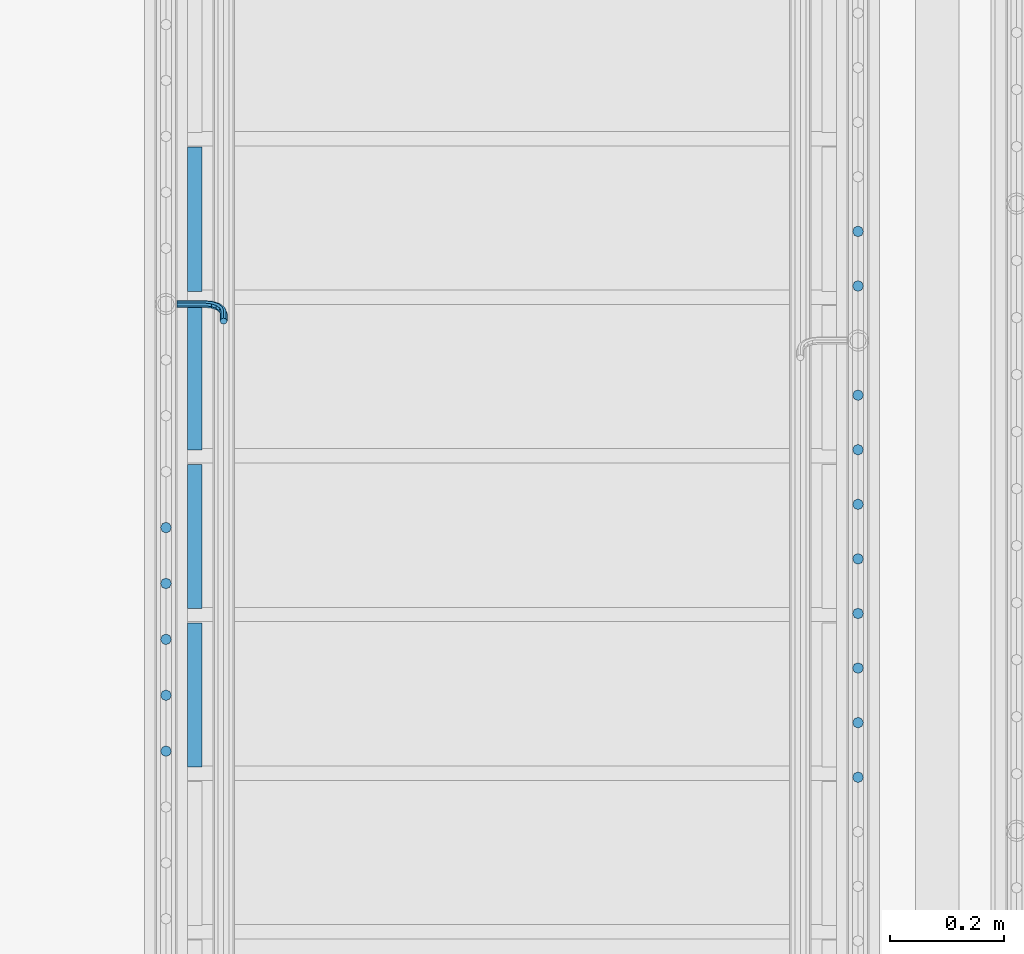
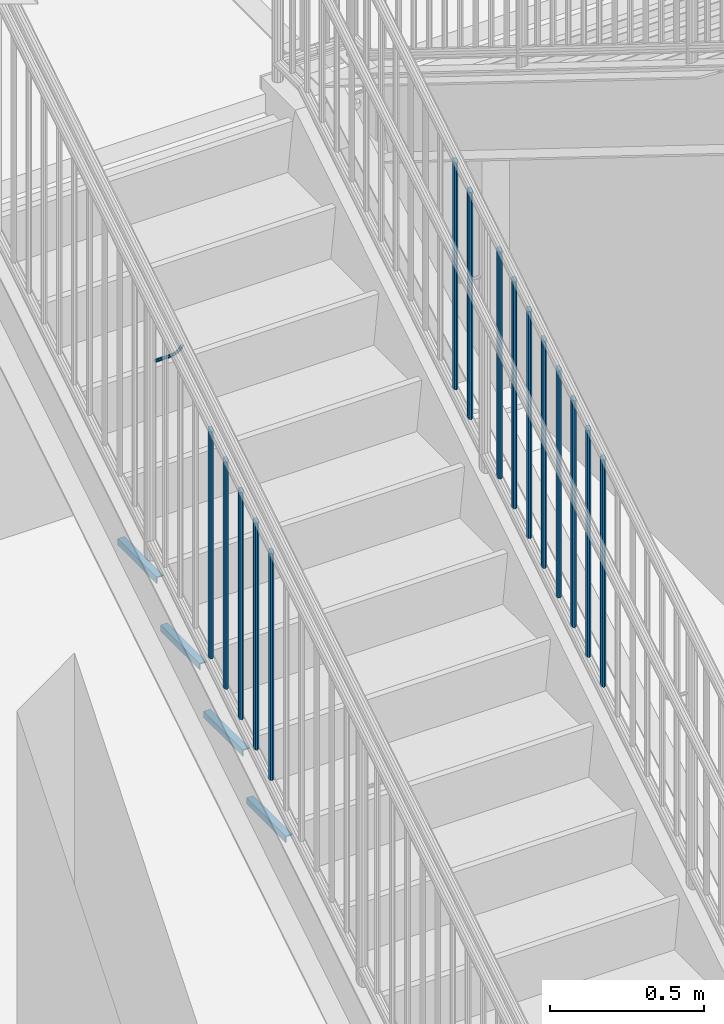
# One storey, part 1268 of 1763: 20 beams, 3 elements without a shape of their own.
"""IFC2X3 building model written with IfcOpenShell, lengths in millimetres."""

from ifc_helpers import new_model, si_unit, frame, origin_with_axes, place, context, subcontext, project, spatial, faceted_brep, material, type_object, element, aggregate, save


model = new_model("IFC2X3")

# Units and contexts
model_context = context("Model", 3, precision=1e-05, world=origin_with_axes())
body_context = subcontext(model_context, "Body", "Model", "MODEL_VIEW")
ifc_project = project(units=[si_unit("LENGTHUNIT", "METRE", prefix="MILLI"), si_unit("AREAUNIT", "SQUARE_METRE"), si_unit("VOLUMEUNIT", "CUBIC_METRE"), si_unit("MASSUNIT", "GRAM", prefix="KILO"), si_unit("TIMEUNIT", "SECOND"), si_unit("PLANEANGLEUNIT", "RADIAN"), si_unit("SOLIDANGLEUNIT", "STERADIAN"), si_unit("THERMODYNAMICTEMPERATUREUNIT", "DEGREE_CELSIUS"), si_unit("LUMINOUSINTENSITYUNIT", "LUMEN")], contexts=[model_context])

# Site, building, storey
site_placement = place(None, origin_with_axes())
site = spatial("IfcSite", under=ifc_project, at=site_placement, CompositionType="ELEMENT")
building_placement = place(site_placement, origin_with_axes())
building = spatial("IfcBuilding", under=site, at=building_placement, Name="Undefined", CompositionType="ELEMENT")
storey_placement = place(building_placement, origin_with_axes())
storey = spatial("IfcBuildingStorey", under=building, at=storey_placement, Name="Undefined", CompositionType="ELEMENT", Elevation=0.0)

# Assembly, beam
assembly_1_placement = place(storey_placement, origin_with_axes())
assembly_1 = element("IfcElementAssembly", 1, at=assembly_1_placement, inside=storey, Name="RAIL", AssemblyPlace="NOTDEFINED", PredefinedType="RIGID_FRAME")
ifc_material = material(Name="STEEL/A36")
beam_type_1 = type_object("IfcBeamType", PredefinedType="NOTDEFINED")
beam_1_placement = place(assembly_1_placement, frame((-86759.4872736811, 34811.546667036, 2863.82335685089), z_axis=(0.0, -0.849698797869672, -0.527268387919127), x_axis=(1.0, 0.0, 0.0)))
beam_1 = element("IfcBeam", 2, at=beam_1_placement, type_object=beam_type_1, material=ifc_material, Name="RAIL", context=body_context, shape_type="Brep", body=[
    faceted_brep([(0.0, -6.34999999999491, 1.45519152283669e-11), (-1.13686837721616e-13, -4.49012806053361, -4.49012806058454), (50.8000030517578, -4.49012806053452, -4.49012806053361), (50.8000030517578, -6.35000000000036, 0.0), (0.0, 0.0, -6.34999990463257), (50.8000030517578, 0.0, -6.34999999999854), (0.0, 4.49012806054088, -4.49012806053452), (50.8000030517578, 4.49012806053452, -4.49012806053361), (0.0, 6.34999999999491, -2.91038304567337e-11), (50.8000030517578, 6.35000000000036, 0.0), (0.0, 4.49012806054088, 4.49012806053452), (50.8000030517578, 4.49012806053452, 4.49012806053361), (0.0, 0.0, 6.34999990463257), (50.8000030517578, 0.0, 6.34999999999854), (0.0, -4.49012806053361, 4.49012806055543), (50.8000030517578, -4.49012806053452, 4.49012806053361), (65.380241824867, -3.44981018867929, 0.0), (64.6684996473195, -1.73151257071549, 4.49012806053361), (62.9502020293439, 2.4168248427668, 6.34999999999854), (61.2319044113829, 6.5651622562491, 4.49012806053361), (60.5201622338354, 8.2834598742138, 0.0), (61.2319044113829, 6.5651622562491, -4.49012806053361), (62.9502020293439, 2.4168248427668, -6.34999999999854), (64.6684996473195, -1.73151257071549, -4.49012806053361), (76.425643354436, 6.12435969732724, -4.49012806053361), (77.7407714149595, 4.8092316367929, 0.0), (73.2506433544331, 9.29935969732742, -6.34999999999854), (70.0756433544302, 12.4743596973276, -4.49012806053361), (68.7605152938922, 13.7894877578619, 0.0), (70.0756433544302, 12.4743596973276, 4.49012806053361), (73.2506433544331, 9.29935969732742, 6.34999999999854), (76.425643354436, 6.12435969732724, 4.49012806053361), (84.2815156224679, 17.8815034044446, -4.49012806053361), (85.9998132404435, 17.1697612268908, 0.0), (80.1331782089983, 19.5998010224093, -6.34999999999854), (75.9848407955142, 21.3180986403731, -4.49012806053361), (74.2665431775386, 22.0298408179269, 0.0), (75.9848407955142, 21.3180986403731, 4.49012806053361), (80.1331782089983, 19.5998010224093, 6.34999999999854), (84.2815156224679, 17.8815034044446, 4.49012806053361), (87.0401311122987, 31.75, -4.49012806053361), (88.9000030517636, 31.75, 0.0), (82.5500030517578, 31.75, -6.34999999999854), (78.0598749912169, 31.75, -4.49012806053361), (76.200003051752, 31.75, 0.0), (78.0598749912169, 31.75, 4.49012806053361), (82.5500030517578, 31.75, 6.34999999999854), (87.0401311122987, 31.75, 4.49012806053361), (87.0401311122987, 57.1500015258789, -4.49012806053361), (88.9000030517636, 57.1500015258789, 0.0), (82.5500030517578, 57.1500015258789, -6.34999999999854), (78.0598749912169, 57.1500015258789, -4.49012806053361), (76.200003051752, 57.1500015258789, 0.0), (78.0598749912169, 57.1500015258789, 4.49012806053361), (82.5500030517578, 57.1500015258789, 6.34999999999854), (87.0401311122987, 57.1500015258789, 4.49012806053361)], [[[0, 1, 2, 3]], [[1, 4, 5, 2]], [[4, 6, 7, 5]], [[6, 8, 9, 7]], [[8, 10, 11, 9]], [[10, 12, 13, 11]], [[12, 14, 15, 13]], [[14, 0, 3, 15]], [[14, 12, 10, 8, 6, 4, 1, 0]], [[15, 3, 16, 17]], [[13, 15, 17, 18]], [[11, 13, 18, 19]], [[9, 11, 19, 20]], [[7, 9, 20, 21]], [[5, 7, 21, 22]], [[2, 5, 22, 23]], [[3, 2, 23, 16]], [[23, 24, 25, 16]], [[22, 26, 24, 23]], [[21, 27, 26, 22]], [[20, 28, 27, 21]], [[19, 29, 28, 20]], [[18, 30, 29, 19]], [[17, 31, 30, 18]], [[16, 25, 31, 17]], [[24, 32, 33, 25]], [[26, 34, 32, 24]], [[27, 35, 34, 26]], [[28, 36, 35, 27]], [[29, 37, 36, 28]], [[30, 38, 37, 29]], [[31, 39, 38, 30]], [[25, 33, 39, 31]], [[32, 40, 41, 33]], [[34, 42, 40, 32]], [[35, 43, 42, 34]], [[36, 44, 43, 35]], [[37, 45, 44, 36]], [[38, 46, 45, 37]], [[39, 47, 46, 38]], [[33, 41, 47, 39]], [[41, 40, 48, 49]], [[40, 42, 50, 48]], [[42, 43, 51, 50]], [[43, 44, 52, 51]], [[44, 45, 53, 52]], [[45, 46, 54, 53]], [[46, 47, 55, 54]], [[47, 41, 49, 55]], [[50, 51, 52, 53, 54, 55, 49, 48]]]),
])

# Assembly, beams
assembly_2_placement = place(storey_placement, origin_with_axes())
assembly_2 = element("IfcElementAssembly", 3, at=assembly_2_placement, inside=storey, Name="RAIL", AssemblyPlace="NOTDEFINED", PredefinedType="RIGID_FRAME")
beam_type_2 = type_object("IfcBeamType", PredefinedType="NOTDEFINED")
beam_2_placement = place(assembly_2_placement, frame((-85559.3372736932, 34939.5142860851, 3185.31072448775), z_axis=(-1.0, 0.0, 0.0), x_axis=(0.0, 0.0, -1.0)))
beam_2 = element("IfcBeam", 4, at=beam_2_placement, type_object=beam_type_2, material=ifc_material, Name="PICKET", context=body_context, shape_type="Brep", body=[
    faceted_brep([(16.5091072770651, -9.52500000000146, 0.0), (18.2402825153672, -6.73519209080405, -6.73519209079677), (919.550864034841, -6.73519209080405, -6.73519209079677), (917.819688796539, -9.52500000000146, 0.0), (22.4197092545201, 0.0, -9.52499999999418), (923.730290773995, 0.0, -9.52499999999418), (26.5991359936734, 6.73519209080405, -6.73519209079677), (927.909717513148, 6.73519209080405, -6.73519209079677), (28.330311231975, 9.52500000000146, 0.0), (929.64089275145, 9.52500000000146, 0.0), (26.5991359936734, 6.73519209080405, 6.73519209079677), (927.909717513148, 6.73519209080405, 6.73519209079677), (22.4197092545201, 0.0, 9.52499999999418), (923.730290773995, 0.0, 9.52499999999418), (18.2402825153672, -6.73519209080405, 6.73519209079677), (919.550864034841, -6.73519209080405, 6.73519209079677)], [[[0, 1, 2, 3]], [[1, 4, 5, 2]], [[4, 6, 7, 5]], [[6, 8, 9, 7]], [[8, 10, 11, 9]], [[10, 12, 13, 11]], [[12, 14, 15, 13]], [[14, 0, 3, 15]], [[13, 15, 3, 2, 5, 7, 9, 11]], [[14, 12, 10, 8, 6, 4, 1, 0]]]),
])
beam_3_placement = place(assembly_2_placement, frame((-85559.3372736932, 34843.3571432281, 3125.64179023867), z_axis=(-1.0, 0.0, 0.0), x_axis=(0.0, 0.0, -1.0)))
beam_3 = element("IfcBeam", 5, at=beam_3_placement, type_object=beam_type_2, material=ifc_material, Name="PICKET", context=body_context, shape_type="Brep", body=[
    faceted_brep([(16.5091072770651, -9.52500000000146, 0.0), (18.2402825153672, -6.73519209080405, -6.73519209079677), (919.550864034841, -6.73519209080405, -6.73519209079677), (917.819688796539, -9.52500000000146, 0.0), (22.4197092545201, 0.0, -9.52499999999418), (923.730290773995, 0.0, -9.52499999999418), (26.5991359936734, 6.73519209080405, -6.73519209079677), (927.909717513148, 6.73519209080405, -6.73519209079677), (28.330311231975, 9.52500000000146, 0.0), (929.64089275145, 9.52500000000146, 0.0), (26.5991359936734, 6.73519209080405, 6.73519209079677), (927.909717513148, 6.73519209080405, 6.73519209079677), (22.4197092545201, 0.0, 9.52499999999418), (923.730290773995, 0.0, 9.52499999999418), (18.2402825153672, -6.73519209080405, 6.73519209079677), (919.550864034841, -6.73519209080405, 6.73519209079677)], [[[0, 1, 2, 3]], [[1, 4, 5, 2]], [[4, 6, 7, 5]], [[6, 8, 9, 7]], [[8, 10, 11, 9]], [[10, 12, 13, 11]], [[12, 14, 15, 13]], [[14, 0, 3, 15]], [[13, 15, 3, 2, 5, 7, 9, 11]], [[14, 12, 10, 8, 6, 4, 1, 0]]]),
])
beam_4_placement = place(assembly_2_placement, frame((-85559.3372736932, 34651.0428575139, 3006.3039217404), z_axis=(-1.0, 0.0, 0.0), x_axis=(0.0, 0.0, -1.0)))
beam_4 = element("IfcBeam", 6, at=beam_4_placement, type_object=beam_type_2, material=ifc_material, Name="PICKET", context=body_context, shape_type="Brep", body=[
    faceted_brep([(16.5091072770651, -9.52500000000146, 0.0), (18.2402825153672, -6.73519209080405, -6.73519209079677), (919.550864034841, -6.73519209080405, -6.73519209079677), (917.819688796539, -9.52500000000146, 0.0), (22.4197092545201, 0.0, -9.52499999999418), (923.730290773995, 0.0, -9.52499999999418), (26.5991359936734, 6.73519209080405, -6.73519209079677), (927.909717513148, 6.73519209080405, -6.73519209079677), (28.330311231975, 9.52500000000146, 0.0), (929.64089275145, 9.52500000000146, 0.0), (26.5991359936734, 6.73519209080405, 6.73519209079677), (927.909717513148, 6.73519209080405, 6.73519209079677), (22.4197092545201, 0.0, 9.52499999999418), (923.730290773995, 0.0, 9.52499999999418), (18.2402825153672, -6.73519209080405, 6.73519209079677), (919.550864034841, -6.73519209080405, 6.73519209079677)], [[[0, 1, 2, 3]], [[1, 4, 5, 2]], [[4, 6, 7, 5]], [[6, 8, 9, 7]], [[8, 10, 11, 9]], [[10, 12, 13, 11]], [[12, 14, 15, 13]], [[14, 0, 3, 15]], [[13, 15, 3, 2, 5, 7, 9, 11]], [[14, 12, 10, 8, 6, 4, 1, 0]]]),
])
beam_5_placement = place(assembly_2_placement, frame((-85559.3372736932, 34554.8857146567, 2946.6349874912), z_axis=(-1.0, 0.0, 0.0), x_axis=(0.0, 0.0, -1.0)))
beam_5 = element("IfcBeam", 7, at=beam_5_placement, type_object=beam_type_2, material=ifc_material, Name="PICKET", context=body_context, shape_type="Brep", body=[
    faceted_brep([(16.5091072770651, -9.52500000000146, 0.0), (18.2402825153672, -6.73519209080405, -6.73519209079677), (919.550864034841, -6.73519209080405, -6.73519209079677), (917.819688796539, -9.52500000000146, 0.0), (22.4197092545201, 0.0, -9.52499999999418), (923.730290773995, 0.0, -9.52499999999418), (26.5991359936734, 6.73519209080405, -6.73519209079677), (927.909717513148, 6.73519209080405, -6.73519209079677), (28.330311231975, 9.52500000000146, 0.0), (929.64089275145, 9.52500000000146, 0.0), (26.5991359936734, 6.73519209080405, 6.73519209079677), (927.909717513148, 6.73519209080405, 6.73519209079677), (22.4197092545201, 0.0, 9.52499999999418), (923.730290773995, 0.0, 9.52499999999418), (18.2402825153672, -6.73519209080405, 6.73519209079677), (919.550864034841, -6.73519209080405, 6.73519209079677)], [[[0, 1, 2, 3]], [[1, 4, 5, 2]], [[4, 6, 7, 5]], [[6, 8, 9, 7]], [[8, 10, 11, 9]], [[10, 12, 13, 11]], [[12, 14, 15, 13]], [[14, 0, 3, 15]], [[13, 15, 3, 2, 5, 7, 9, 11]], [[14, 12, 10, 8, 6, 4, 1, 0]]]),
])
beam_6_placement = place(assembly_2_placement, frame((-85559.3372736932, 34458.7285717995, 2886.96605324201), z_axis=(-1.0, 0.0, 0.0), x_axis=(0.0, 0.0, -1.0)))
beam_6 = element("IfcBeam", 8, at=beam_6_placement, type_object=beam_type_2, material=ifc_material, Name="PICKET", context=body_context, shape_type="Brep", body=[
    faceted_brep([(16.5091072770651, -9.52500000000146, 0.0), (18.2402825153672, -6.73519209080405, -6.73519209079677), (919.550864034841, -6.73519209080405, -6.73519209079677), (917.819688796539, -9.52500000000146, 0.0), (22.4197092545201, 0.0, -9.52499999999418), (923.730290773995, 0.0, -9.52499999999418), (26.5991359936734, 6.73519209080405, -6.73519209079677), (927.909717513148, 6.73519209080405, -6.73519209079677), (28.330311231975, 9.52500000000146, 0.0), (929.64089275145, 9.52500000000146, 0.0), (26.5991359936734, 6.73519209080405, 6.73519209079677), (927.909717513148, 6.73519209080405, 6.73519209079677), (22.4197092545201, 0.0, 9.52499999999418), (923.730290773995, 0.0, 9.52499999999418), (18.2402825153672, -6.73519209080405, 6.73519209079677), (919.550864034841, -6.73519209080405, 6.73519209079677)], [[[0, 1, 2, 3]], [[1, 4, 5, 2]], [[4, 6, 7, 5]], [[6, 8, 9, 7]], [[8, 10, 11, 9]], [[10, 12, 13, 11]], [[12, 14, 15, 13]], [[14, 0, 3, 15]], [[13, 15, 3, 2, 5, 7, 9, 11]], [[14, 12, 10, 8, 6, 4, 1, 0]]]),
])
beam_7_placement = place(assembly_2_placement, frame((-85559.3372736932, 34362.5714289422, 2827.29711899281), z_axis=(-1.0, 0.0, 0.0), x_axis=(0.0, 0.0, -1.0)))
beam_7 = element("IfcBeam", 9, at=beam_7_placement, type_object=beam_type_2, material=ifc_material, Name="PICKET", context=body_context, shape_type="Brep", body=[
    faceted_brep([(16.5091072770651, -9.52500000000146, 0.0), (18.2402825153672, -6.73519209080405, -6.73519209079677), (919.550864034841, -6.73519209080405, -6.73519209079677), (917.819688796539, -9.52500000000146, 0.0), (22.4197092545201, 0.0, -9.52499999999418), (923.730290773995, 0.0, -9.52499999999418), (26.5991359936734, 6.73519209080405, -6.73519209079677), (927.909717513148, 6.73519209080405, -6.73519209079677), (28.330311231975, 9.52500000000146, 0.0), (929.64089275145, 9.52500000000146, 0.0), (26.5991359936734, 6.73519209080405, 6.73519209079677), (927.909717513148, 6.73519209080405, 6.73519209079677), (22.4197092545201, 0.0, 9.52499999999418), (923.730290773995, 0.0, 9.52499999999418), (18.2402825153672, -6.73519209080405, 6.73519209079677), (919.550864034841, -6.73519209080405, 6.73519209079677)], [[[0, 1, 2, 3]], [[1, 4, 5, 2]], [[4, 6, 7, 5]], [[6, 8, 9, 7]], [[8, 10, 11, 9]], [[10, 12, 13, 11]], [[12, 14, 15, 13]], [[14, 0, 3, 15]], [[13, 15, 3, 2, 5, 7, 9, 11]], [[14, 12, 10, 8, 6, 4, 1, 0]]]),
])
beam_8_placement = place(assembly_2_placement, frame((-85559.3372736932, 34266.414286085, 2767.62818474362), z_axis=(-1.0, 0.0, 0.0), x_axis=(0.0, 0.0, -1.0)))
beam_8 = element("IfcBeam", 10, at=beam_8_placement, type_object=beam_type_2, material=ifc_material, Name="PICKET", context=body_context, shape_type="Brep", body=[
    faceted_brep([(16.5091072770651, -9.52500000000146, 0.0), (18.2402825153672, -6.73519209080405, -6.73519209079677), (919.550864034841, -6.73519209080405, -6.73519209079677), (917.819688796539, -9.52500000000146, 0.0), (22.4197092545201, 0.0, -9.52499999999418), (923.730290773995, 0.0, -9.52499999999418), (26.5991359936734, 6.73519209080405, -6.73519209079677), (927.909717513148, 6.73519209080405, -6.73519209079677), (28.330311231975, 9.52500000000146, 0.0), (929.64089275145, 9.52500000000146, 0.0), (26.5991359936734, 6.73519209080405, 6.73519209079677), (927.909717513148, 6.73519209080405, 6.73519209079677), (22.4197092545201, 0.0, 9.52499999999418), (923.730290773995, 0.0, 9.52499999999418), (18.2402825153672, -6.73519209080405, 6.73519209079677), (919.550864034841, -6.73519209080405, 6.73519209079677)], [[[0, 1, 2, 3]], [[1, 4, 5, 2]], [[4, 6, 7, 5]], [[6, 8, 9, 7]], [[8, 10, 11, 9]], [[10, 12, 13, 11]], [[12, 14, 15, 13]], [[14, 0, 3, 15]], [[13, 15, 3, 2, 5, 7, 9, 11]], [[14, 12, 10, 8, 6, 4, 1, 0]]]),
])
beam_9_placement = place(assembly_2_placement, frame((-85559.3372736932, 34170.2571432278, 2707.95925049442), z_axis=(-1.0, 0.0, 0.0), x_axis=(0.0, 0.0, -1.0)))
beam_9 = element("IfcBeam", 11, at=beam_9_placement, type_object=beam_type_2, material=ifc_material, Name="PICKET", context=body_context, shape_type="Brep", body=[
    faceted_brep([(16.5091072770651, -9.52500000000146, 0.0), (18.2402825153672, -6.73519209080405, -6.73519209079677), (919.550864034841, -6.73519209080405, -6.73519209079677), (917.819688796539, -9.52500000000146, 0.0), (22.4197092545201, 0.0, -9.52499999999418), (923.730290773995, 0.0, -9.52499999999418), (26.5991359936734, 6.73519209080405, -6.73519209079677), (927.909717513148, 6.73519209080405, -6.73519209079677), (28.330311231975, 9.52500000000146, 0.0), (929.64089275145, 9.52500000000146, 0.0), (26.5991359936734, 6.73519209080405, 6.73519209079677), (927.909717513148, 6.73519209080405, 6.73519209079677), (22.4197092545201, 0.0, 9.52499999999418), (923.730290773995, 0.0, 9.52499999999418), (18.2402825153672, -6.73519209080405, 6.73519209079677), (919.550864034841, -6.73519209080405, 6.73519209079677)], [[[0, 1, 2, 3]], [[1, 4, 5, 2]], [[4, 6, 7, 5]], [[6, 8, 9, 7]], [[8, 10, 11, 9]], [[10, 12, 13, 11]], [[12, 14, 15, 13]], [[14, 0, 3, 15]], [[13, 15, 3, 2, 5, 7, 9, 11]], [[14, 12, 10, 8, 6, 4, 1, 0]]]),
])
beam_10_placement = place(assembly_2_placement, frame((-85559.3372736932, 34074.1000003706, 2648.29031624522), z_axis=(-1.0, 0.0, 0.0), x_axis=(0.0, 0.0, -1.0)))
beam_10 = element("IfcBeam", 12, at=beam_10_placement, type_object=beam_type_2, material=ifc_material, Name="PICKET", context=body_context, shape_type="Brep", body=[
    faceted_brep([(16.5091072770651, -9.52500000000146, 0.0), (18.2402825153672, -6.73519209080405, -6.73519209079677), (919.550864034841, -6.73519209080405, -6.73519209079677), (917.819688796539, -9.52500000000146, 0.0), (22.4197092545201, 0.0, -9.52499999999418), (923.730290773995, 0.0, -9.52499999999418), (26.5991359936734, 6.73519209080405, -6.73519209079677), (927.909717513148, 6.73519209080405, -6.73519209079677), (28.330311231975, 9.52500000000146, 0.0), (929.64089275145, 9.52500000000146, 0.0), (26.5991359936734, 6.73519209080405, 6.73519209079677), (927.909717513148, 6.73519209080405, 6.73519209079677), (22.4197092545201, 0.0, 9.52499999999418), (923.730290773995, 0.0, 9.52499999999418), (18.2402825153672, -6.73519209080405, 6.73519209079677), (919.550864034841, -6.73519209080405, 6.73519209079677)], [[[0, 1, 2, 3]], [[1, 4, 5, 2]], [[4, 6, 7, 5]], [[6, 8, 9, 7]], [[8, 10, 11, 9]], [[10, 12, 13, 11]], [[12, 14, 15, 13]], [[14, 0, 3, 15]], [[13, 15, 3, 2, 5, 7, 9, 11]], [[14, 12, 10, 8, 6, 4, 1, 0]]]),
])
beam_11_placement = place(assembly_2_placement, frame((-85559.3372736932, 33977.9428575134, 2588.62138199603), z_axis=(-1.0, 0.0, 0.0), x_axis=(0.0, 0.0, -1.0)))
beam_11 = element("IfcBeam", 13, at=beam_11_placement, type_object=beam_type_2, material=ifc_material, Name="PICKET", context=body_context, shape_type="Brep", body=[
    faceted_brep([(16.5091072770651, -9.52500000000146, 0.0), (18.2402825153672, -6.73519209080405, -6.73519209079677), (919.550864034841, -6.73519209080405, -6.73519209079677), (917.819688796539, -9.52500000000146, 0.0), (22.4197092545201, 0.0, -9.52499999999418), (923.730290773995, 0.0, -9.52499999999418), (26.5991359936734, 6.73519209080405, -6.73519209079677), (927.909717513148, 6.73519209080405, -6.73519209079677), (28.330311231975, 9.52500000000146, 0.0), (929.64089275145, 9.52500000000146, 0.0), (26.5991359936734, 6.73519209080405, 6.73519209079677), (927.909717513148, 6.73519209080405, 6.73519209079677), (22.4197092545201, 0.0, 9.52499999999418), (923.730290773995, 0.0, 9.52499999999418), (18.2402825153672, -6.73519209080405, 6.73519209079677), (919.550864034841, -6.73519209080405, 6.73519209079677)], [[[0, 1, 2, 3]], [[1, 4, 5, 2]], [[4, 6, 7, 5]], [[6, 8, 9, 7]], [[8, 10, 11, 9]], [[10, 12, 13, 11]], [[12, 14, 15, 13]], [[14, 0, 3, 15]], [[13, 15, 3, 2, 5, 7, 9, 11]], [[14, 12, 10, 8, 6, 4, 1, 0]]]),
])
aggregate(assembly_2, [beam_2, beam_3, beam_4, beam_5, beam_6, beam_7, beam_8, beam_9, beam_10, beam_11])

# Beam
beam_12_placement = place(assembly_1_placement, frame((-86778.5372736927, 34417.725714655, 2861.52231901041), z_axis=(-1.0, 0.0, 0.0), x_axis=(0.0, 0.0, -1.0)))
beam_12 = element("IfcBeam", 14, at=beam_12_placement, type_object=beam_type_2, material=ifc_material, Name="PICKET", context=body_context, shape_type="Brep", body=[
    faceted_brep([(16.5091072770651, -9.52500000000146, 0.0), (18.2402825153672, -6.73519209080405, -6.73519209079677), (919.550864034841, -6.73519209080405, -6.73519209079677), (917.819688796539, -9.52500000000146, 0.0), (22.4197092545201, 0.0, -9.52499999999418), (923.730290773995, 0.0, -9.52499999999418), (26.5991359936734, 6.73519209080405, -6.73519209079677), (927.909717513148, 6.73519209080405, -6.73519209079677), (28.330311231975, 9.52500000000146, 0.0), (929.64089275145, 9.52500000000146, 0.0), (26.5991359936734, 6.73519209080405, 6.73519209079677), (927.909717513148, 6.73519209080405, 6.73519209079677), (22.4197092545201, 0.0, 9.52499999999418), (923.730290773995, 0.0, 9.52499999999418), (18.2402825153672, -6.73519209080405, 6.73519209079677), (919.550864034841, -6.73519209080405, 6.73519209079677)], [[[0, 1, 2, 3]], [[1, 4, 5, 2]], [[4, 6, 7, 5]], [[6, 8, 9, 7]], [[8, 10, 11, 9]], [[10, 12, 13, 11]], [[12, 14, 15, 13]], [[14, 0, 3, 15]], [[13, 15, 3, 2, 5, 7, 9, 11]], [[14, 12, 10, 8, 6, 4, 1, 0]]]),
])

beam_13_placement = place(assembly_1_placement, frame((-86778.5372736927, 34319.2704765598, 2800.42733476068), z_axis=(-1.0, 0.0, 0.0), x_axis=(0.0, 0.0, -1.0)))
beam_13 = element("IfcBeam", 15, at=beam_13_placement, type_object=beam_type_2, material=ifc_material, Name="PICKET", context=body_context, shape_type="Brep", body=[
    faceted_brep([(16.5091072770651, -9.52500000000146, 0.0), (18.2402825153672, -6.73519209080405, -6.73519209079677), (919.550864034841, -6.73519209080405, -6.73519209079677), (917.819688796539, -9.52500000000146, 0.0), (22.4197092545201, 0.0, -9.52499999999418), (923.730290773995, 0.0, -9.52499999999418), (26.5991359936734, 6.73519209080405, -6.73519209079677), (927.909717513148, 6.73519209080405, -6.73519209079677), (28.330311231975, 9.52500000000146, 0.0), (929.64089275145, 9.52500000000146, 0.0), (26.5991359936734, 6.73519209080405, 6.73519209079677), (927.909717513148, 6.73519209080405, 6.73519209079677), (22.4197092545201, 0.0, 9.52499999999418), (923.730290773995, 0.0, 9.52499999999418), (18.2402825153672, -6.73519209080405, 6.73519209079677), (919.550864034841, -6.73519209080405, 6.73519209079677)], [[[0, 1, 2, 3]], [[1, 4, 5, 2]], [[4, 6, 7, 5]], [[6, 8, 9, 7]], [[8, 10, 11, 9]], [[10, 12, 13, 11]], [[12, 14, 15, 13]], [[14, 0, 3, 15]], [[13, 15, 3, 2, 5, 7, 9, 11]], [[14, 12, 10, 8, 6, 4, 1, 0]]]),
])

beam_14_placement = place(assembly_1_placement, frame((-86778.5372736927, 34220.8152384645, 2739.33235051095), z_axis=(-1.0, 0.0, 0.0), x_axis=(0.0, 0.0, -1.0)))
beam_14 = element("IfcBeam", 16, at=beam_14_placement, type_object=beam_type_2, material=ifc_material, Name="PICKET", context=body_context, shape_type="Brep", body=[
    faceted_brep([(16.5091072770651, -9.52500000000146, 0.0), (18.2402825153672, -6.73519209080405, -6.73519209079677), (919.550864034841, -6.73519209080405, -6.73519209079677), (917.819688796539, -9.52500000000146, 0.0), (22.4197092545201, 0.0, -9.52499999999418), (923.730290773995, 0.0, -9.52499999999418), (26.5991359936734, 6.73519209080405, -6.73519209079677), (927.909717513148, 6.73519209080405, -6.73519209079677), (28.330311231975, 9.52500000000146, 0.0), (929.64089275145, 9.52500000000146, 0.0), (26.5991359936734, 6.73519209080405, 6.73519209079677), (927.909717513148, 6.73519209080405, 6.73519209079677), (22.4197092545201, 0.0, 9.52499999999418), (923.730290773995, 0.0, 9.52499999999418), (18.2402825153672, -6.73519209080405, 6.73519209079677), (919.550864034841, -6.73519209080405, 6.73519209079677)], [[[0, 1, 2, 3]], [[1, 4, 5, 2]], [[4, 6, 7, 5]], [[6, 8, 9, 7]], [[8, 10, 11, 9]], [[10, 12, 13, 11]], [[12, 14, 15, 13]], [[14, 0, 3, 15]], [[13, 15, 3, 2, 5, 7, 9, 11]], [[14, 12, 10, 8, 6, 4, 1, 0]]]),
])

beam_15_placement = place(assembly_1_placement, frame((-86778.5372736927, 34122.3600003693, 2678.23736626122), z_axis=(-1.0, 0.0, 0.0), x_axis=(0.0, 0.0, -1.0)))
beam_15 = element("IfcBeam", 17, at=beam_15_placement, type_object=beam_type_2, material=ifc_material, Name="PICKET", context=body_context, shape_type="Brep", body=[
    faceted_brep([(16.5091072770651, -9.52500000000146, 0.0), (18.2402825153672, -6.73519209080405, -6.73519209079677), (919.550864034841, -6.73519209080405, -6.73519209079677), (917.819688796539, -9.52500000000146, 0.0), (22.4197092545201, 0.0, -9.52499999999418), (923.730290773995, 0.0, -9.52499999999418), (26.5991359936734, 6.73519209080405, -6.73519209079677), (927.909717513148, 6.73519209080405, -6.73519209079677), (28.330311231975, 9.52500000000146, 0.0), (929.64089275145, 9.52500000000146, 0.0), (26.5991359936734, 6.73519209080405, 6.73519209079677), (927.909717513148, 6.73519209080405, 6.73519209079677), (22.4197092545201, 0.0, 9.52499999999418), (923.730290773995, 0.0, 9.52499999999418), (18.2402825153672, -6.73519209080405, 6.73519209079677), (919.550864034841, -6.73519209080405, 6.73519209079677)], [[[0, 1, 2, 3]], [[1, 4, 5, 2]], [[4, 6, 7, 5]], [[6, 8, 9, 7]], [[8, 10, 11, 9]], [[10, 12, 13, 11]], [[12, 14, 15, 13]], [[14, 0, 3, 15]], [[13, 15, 3, 2, 5, 7, 9, 11]], [[14, 12, 10, 8, 6, 4, 1, 0]]]),
])

beam_16_placement = place(assembly_1_placement, frame((-86778.5372736927, 34023.9047622741, 2617.14238201149), z_axis=(-1.0, 0.0, 0.0), x_axis=(0.0, 0.0, -1.0)))
beam_16 = element("IfcBeam", 18, at=beam_16_placement, type_object=beam_type_2, material=ifc_material, Name="PICKET", context=body_context, shape_type="Brep", body=[
    faceted_brep([(16.5091072770651, -9.52500000000146, 0.0), (18.2402825153672, -6.73519209080405, -6.73519209079677), (919.550864034841, -6.73519209080405, -6.73519209079677), (917.819688796539, -9.52500000000146, 0.0), (22.4197092545201, 0.0, -9.52499999999418), (923.730290773995, 0.0, -9.52499999999418), (26.5991359936734, 6.73519209080405, -6.73519209079677), (927.909717513148, 6.73519209080405, -6.73519209079677), (28.330311231975, 9.52500000000146, 0.0), (929.64089275145, 9.52500000000146, 0.0), (26.5991359936734, 6.73519209080405, 6.73519209079677), (927.909717513148, 6.73519209080405, 6.73519209079677), (22.4197092545201, 0.0, 9.52499999999418), (923.730290773995, 0.0, 9.52499999999418), (18.2402825153672, -6.73519209080405, 6.73519209079677), (919.550864034841, -6.73519209080405, 6.73519209079677)], [[[0, 1, 2, 3]], [[1, 4, 5, 2]], [[4, 6, 7, 5]], [[6, 8, 9, 7]], [[8, 10, 11, 9]], [[10, 12, 13, 11]], [[12, 14, 15, 13]], [[14, 0, 3, 15]], [[13, 15, 3, 2, 5, 7, 9, 11]], [[14, 12, 10, 8, 6, 4, 1, 0]]]),
])

aggregate(assembly_1, [beam_12, beam_13, beam_14, beam_15, beam_16, beam_1])

# Assembly, beams
assembly_3_placement = place(storey_placement, origin_with_axes())
assembly_3 = element("IfcElementAssembly", 19, at=assembly_3_placement, inside=storey, Name="STRINGER", AssemblyPlace="NOTDEFINED", PredefinedType="RIGID_FRAME")
beam_type_3 = type_object("IfcBeamType", Name="L1X1X1/8", PredefinedType="NOTDEFINED")
beam_17_placement = place(assembly_3_placement, frame((-86727.7372739122, 34834.0511407179, 1971.90178590486), z_axis=(1.0, 0.0, 0.0), x_axis=(0.0, 1.0, 0.0)))
beam_17 = element("IfcBeam", 20, at=beam_17_placement, type_object=beam_type_3, material=ifc_material, Name="ANGLE", ObjectType="L1X1X1/8", context=body_context, shape_type="Brep", body=[
    faceted_brep([(3.93434019839663e-12, 12.6999999999978, -12.6999998092651), (-1.31614667686587e-12, 12.6999999999978, 12.6999998092651), (254.0, 12.69999981, 12.6999998099927), (254.0, 12.69999981, -12.6999998099927), (-1.06936913171421e-12, 9.52499999999854, 12.699999332428), (254.0, 9.52499985799977, 12.6999998099927), (0.0, 9.52499985799977, -9.52499985799659), (254.0, 9.52499985799977, -9.52499985799659), (0.0, -12.69999981, -9.52499985799659), (254.0, -12.69999981, -9.52499985799659), (0.0, -12.69999981, -12.6999998099927), (254.0, -12.69999981, -12.6999998099927)], [[[0, 1, 2, 3]], [[1, 4, 5, 2]], [[4, 6, 7, 5]], [[6, 8, 9, 7]], [[8, 10, 11, 9]], [[10, 0, 3, 11]], [[5, 7, 9, 11, 3, 2]], [[10, 8, 6, 4, 1, 0]]]),
])
beam_18_placement = place(assembly_3_placement, frame((-86727.7372739122, 34554.6511407179, 1798.52410733343), z_axis=(1.0, 0.0, 0.0), x_axis=(0.0, 1.0, 0.0)))
beam_18 = element("IfcBeam", 21, at=beam_18_placement, type_object=beam_type_3, material=ifc_material, Name="ANGLE", ObjectType="L1X1X1/8", context=body_context, shape_type="Brep", body=[
    faceted_brep([(3.93434019839663e-12, 12.6999999999978, -12.6999998092651), (-1.31614667686587e-12, 12.6999999999978, 12.6999998092651), (254.0, 12.69999981, 12.6999998099927), (254.0, 12.69999981, -12.6999998099927), (-1.06936913171421e-12, 9.52499999999854, 12.699999332428), (254.0, 9.52499985799977, 12.6999998099927), (0.0, 9.52499985799977, -9.52499985799659), (254.0, 9.52499985799977, -9.52499985799659), (0.0, -12.69999981, -9.52499985799659), (254.0, -12.69999981, -9.52499985799659), (0.0, -12.69999981, -12.6999998099927), (254.0, -12.69999981, -12.6999998099927)], [[[0, 1, 2, 3]], [[1, 4, 5, 2]], [[4, 6, 7, 5]], [[6, 8, 9, 7]], [[8, 10, 11, 9]], [[10, 0, 3, 11]], [[5, 7, 9, 11, 3, 2]], [[10, 8, 6, 4, 1, 0]]]),
])
beam_19_placement = place(assembly_3_placement, frame((-86727.7372739122, 34275.2511407179, 1625.146428762), z_axis=(1.0, 0.0, 0.0), x_axis=(0.0, 1.0, 0.0)))
beam_19 = element("IfcBeam", 22, at=beam_19_placement, type_object=beam_type_3, material=ifc_material, Name="ANGLE", ObjectType="L1X1X1/8", context=body_context, shape_type="Brep", body=[
    faceted_brep([(3.93434019839663e-12, 12.6999999999978, -12.6999998092651), (-1.31614667686587e-12, 12.6999999999978, 12.6999998092651), (254.0, 12.69999981, 12.6999998099927), (254.0, 12.69999981, -12.6999998099927), (-1.06936913171421e-12, 9.52499999999854, 12.699999332428), (254.0, 9.52499985799977, 12.6999998099927), (0.0, 9.52499985799977, -9.52499985799659), (254.0, 9.52499985799977, -9.52499985799659), (0.0, -12.69999981, -9.52499985799659), (254.0, -12.69999981, -9.52499985799659), (0.0, -12.69999981, -12.6999998099927), (254.0, -12.69999981, -12.6999998099927)], [[[0, 1, 2, 3]], [[1, 4, 5, 2]], [[4, 6, 7, 5]], [[6, 8, 9, 7]], [[8, 10, 11, 9]], [[10, 0, 3, 11]], [[5, 7, 9, 11, 3, 2]], [[10, 8, 6, 4, 1, 0]]]),
])
beam_20_placement = place(assembly_3_placement, frame((-86727.7372739122, 33995.8511407179, 1451.76875019058), z_axis=(1.0, 0.0, 0.0), x_axis=(0.0, 1.0, 0.0)))
beam_20 = element("IfcBeam", 23, at=beam_20_placement, type_object=beam_type_3, material=ifc_material, Name="ANGLE", ObjectType="L1X1X1/8", context=body_context, shape_type="Brep", body=[
    faceted_brep([(3.93434019839663e-12, 12.6999999999978, -12.6999998092651), (-1.31614667686587e-12, 12.6999999999978, 12.6999998092651), (254.0, 12.69999981, 12.6999998099927), (254.0, 12.69999981, -12.6999998099927), (-1.06936913171421e-12, 9.52499999999854, 12.699999332428), (254.0, 9.52499985799977, 12.6999998099927), (0.0, 9.52499985799977, -9.52499985799659), (254.0, 9.52499985799977, -9.52499985799659), (0.0, -12.69999981, -9.52499985799659), (254.0, -12.69999981, -9.52499985799659), (0.0, -12.69999981, -12.6999998099927), (254.0, -12.69999981, -12.6999998099927)], [[[0, 1, 2, 3]], [[1, 4, 5, 2]], [[4, 6, 7, 5]], [[6, 8, 9, 7]], [[8, 10, 11, 9]], [[10, 0, 3, 11]], [[5, 7, 9, 11, 3, 2]], [[10, 8, 6, 4, 1, 0]]]),
])
aggregate(assembly_3, [beam_17, beam_18, beam_19, beam_20])

save(model, "model.ifc")
